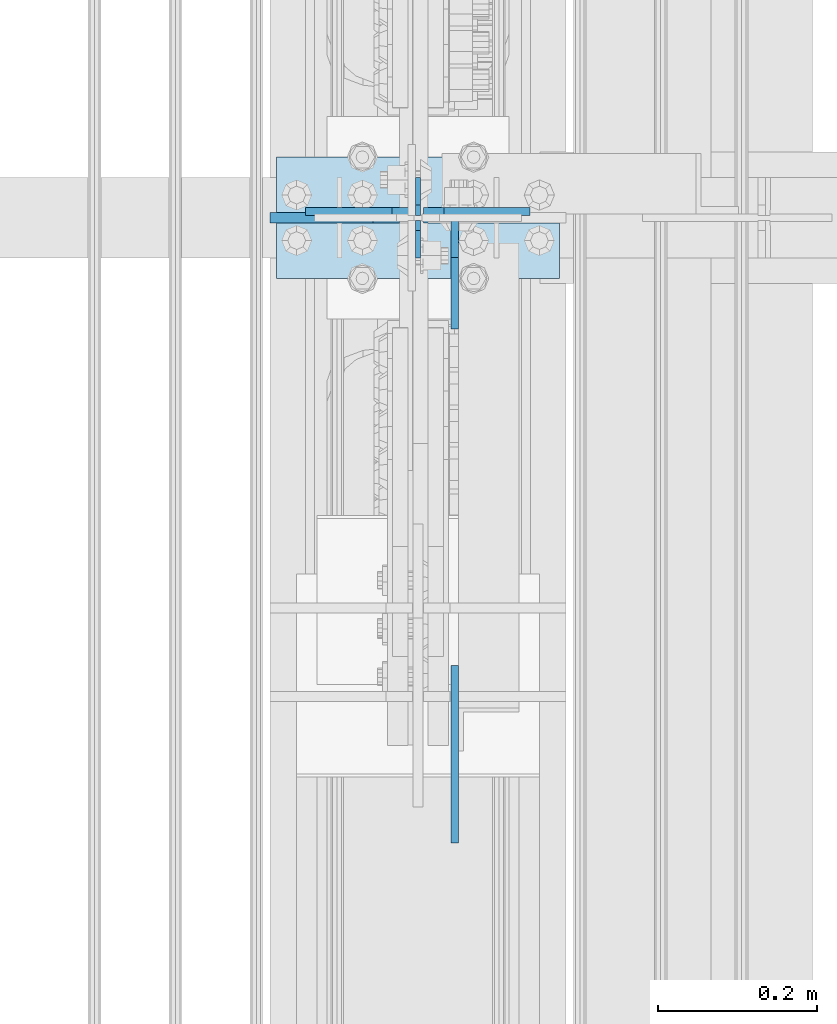
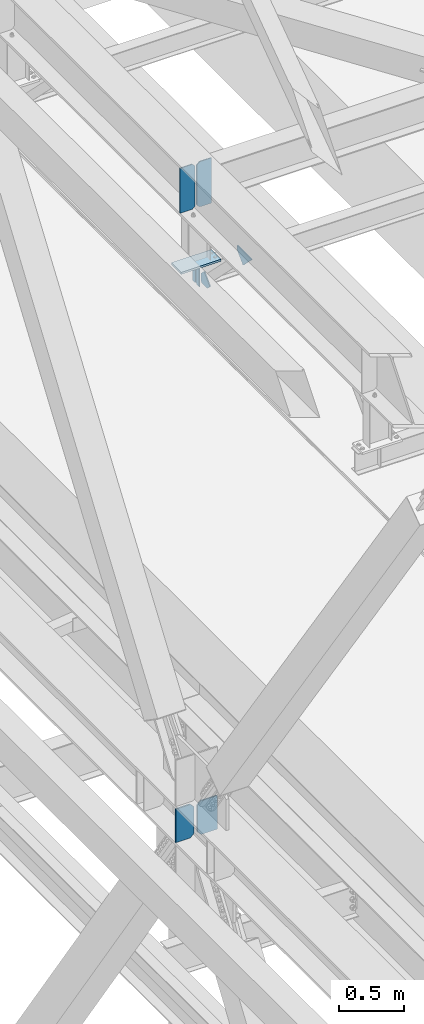
# One storey, part 3348 of 3843: 9 plates, 4 elements without a shape of their own.
"""IFC2X3 building model written with IfcOpenShell, lengths in millimetres."""

from ifc_helpers import new_model, si_unit, frame, origin_with_axes, place, context, subcontext, project, spatial, faceted_brep, material, type_object, element, aggregate, save


model = new_model("IFC2X3")

# Units and contexts
model_context = context("Model", 3, precision=1e-05, world=origin_with_axes())
body_context = subcontext(model_context, "Body", "Model", "MODEL_VIEW")
ifc_project = project(units=[si_unit("LENGTHUNIT", "METRE", prefix="MILLI"), si_unit("AREAUNIT", "SQUARE_METRE"), si_unit("VOLUMEUNIT", "CUBIC_METRE"), si_unit("MASSUNIT", "GRAM", prefix="KILO"), si_unit("TIMEUNIT", "SECOND"), si_unit("PLANEANGLEUNIT", "RADIAN"), si_unit("SOLIDANGLEUNIT", "STERADIAN"), si_unit("THERMODYNAMICTEMPERATUREUNIT", "DEGREE_CELSIUS"), si_unit("LUMINOUSINTENSITYUNIT", "LUMEN")], contexts=[model_context])

# Site, building, storey
site_placement = place(None, origin_with_axes())
site = spatial("IfcSite", under=ifc_project, at=site_placement, CompositionType="ELEMENT")
building_placement = place(site_placement, origin_with_axes())
building = spatial("IfcBuilding", under=site, at=building_placement, Name="Undefined", CompositionType="ELEMENT")
storey_placement = place(building_placement, origin_with_axes())
storey = spatial("IfcBuildingStorey", under=building, at=storey_placement, Name="Undefined", CompositionType="ELEMENT", Elevation=0.0)

# Assembly, plates
assembly_1_placement = place(storey_placement, origin_with_axes())
assembly_1 = element("IfcElementAssembly", 1, at=assembly_1_placement, inside=storey, Name="BEAM", AssemblyPlace="NOTDEFINED", PredefinedType="RIGID_FRAME")
ifc_material = material(Name="STEEL/A572-50")
plate_type_1 = type_object("IfcPlateType", PredefinedType="NOTDEFINED")
plate_1_placement = place(assembly_1_placement, frame((36576.0000030517, 71501.0, 41495.6625), z_axis=(0.0, 0.0, -1.0), x_axis=(0.0, -1.0, 0.0)))
plate_1 = element("IfcPlate", 2, at=plate_1_placement, type_object=plate_type_1, material=ifc_material, Name="PLATE", context=body_context, shape_type="Brep", body=[
    faceted_brep([(0.0, -3.17499999999927, 0.0), (0.0, -3.17500000000291, 187.324999999997), (0.0, 3.17500000000291, 187.324999999997), (0.0, 3.17499999999927, 0.0), (34.9250001907349, -3.17500000000291, 187.324999999997), (34.9250001907349, 3.17500000000291, 187.324999999997), (47.625, -3.17500000000291, 174.625000190732), (47.625, 3.17500000000291, 174.625000190732), (47.625, -3.17499999999927, 12.6999998092651), (47.625, 3.17499999999927, 12.6999998092651), (34.9250001907349, -3.17499999999927, 0.0), (34.9250001907349, 3.17499999999927, 0.0)], [[[0, 1, 2, 3]], [[1, 4, 5, 2]], [[4, 6, 7, 5]], [[6, 8, 9, 7]], [[8, 10, 11, 9]], [[10, 0, 3, 11]], [[5, 7, 9, 11, 3, 2]], [[10, 8, 6, 4, 1, 0]]]),
])
plate_2_placement = place(assembly_1_placement, frame((36576.0000030517, 71399.4, 41495.6625), z_axis=(0.0, 0.0, -1.0), x_axis=(0.0, 1.0, 0.0)))
plate_2 = element("IfcPlate", 3, at=plate_2_placement, type_object=plate_type_1, material=ifc_material, Name="PLATE", context=body_context, shape_type="Brep", body=[
    faceted_brep([(0.0, -3.17499999999927, 0.0), (0.0, -3.17500000000291, 187.324999999997), (0.0, 3.17500000000291, 187.324999999997), (0.0, 3.17499999999927, 0.0), (34.9250001907349, -3.17500000000291, 187.324999999997), (34.9250001907349, 3.17500000000291, 187.324999999997), (47.625, -3.17500000000291, 174.625000190732), (47.625, 3.17500000000291, 174.625000190732), (47.625, -3.17499999999927, 12.6999998092651), (47.625, 3.17499999999927, 12.6999998092651), (34.9250001907349, -3.17499999999927, 0.0), (34.9250001907349, 3.17499999999927, 0.0)], [[[0, 1, 2, 3]], [[1, 4, 5, 2]], [[4, 6, 7, 5]], [[6, 8, 9, 7]], [[8, 10, 11, 9]], [[10, 0, 3, 11]], [[5, 7, 9, 11, 3, 2]], [[10, 8, 6, 4, 1, 0]]]),
])

# Assembly, plate
assembly_2_placement = place(storey_placement, origin_with_axes())
assembly_2 = element("IfcElementAssembly", 4, at=assembly_2_placement, inside=storey, Name="BEAM", AssemblyPlace="NOTDEFINED", PredefinedType="RIGID_FRAME")
plate_type_2 = type_object("IfcPlateType", PredefinedType="NOTDEFINED")
plate_3_placement = place(assembly_2_placement, frame((36583.14375, 71450.199998691, 36093.4), z_axis=(1.0, 0.0, 0.0), x_axis=(0.0, 0.0, 1.0)))
plate_3 = element("IfcPlate", 5, at=plate_3_placement, type_object=plate_type_2, material=ifc_material, Name="CB_BEAM", context=body_context, shape_type="Brep", body=[
    faceted_brep([(0.0, -6.34999999999854, 33.3375015258789), (0.0, -6.34999999999854, 178.59375), (0.0, 6.34999999999854, 178.59375), (0.0, 6.34999999999854, 33.3375015258789), (317.499999999985, -6.34999999999854, 178.59375), (317.499999999985, 6.34999999999854, 178.59375), (317.499999999985, -6.34999999999854, 33.3375015258789), (317.499999999985, 6.34999999999854, 33.3375015258789), (284.162498474107, -6.34999999999854, 0.0), (284.162498474107, 6.34999999999854, 0.0), (33.3375015258789, -6.34999999999854, 0.0), (33.3375015258789, 6.34999999999854, 0.0)], [[[0, 1, 2, 3]], [[1, 4, 5, 2]], [[4, 6, 7, 5]], [[6, 8, 9, 7]], [[8, 10, 11, 9]], [[10, 0, 3, 11]], [[5, 7, 9, 11, 3, 2]], [[10, 8, 6, 4, 1, 0]]]),
])

assembly_3_placement = place(storey_placement, origin_with_axes())
assembly_3 = element("IfcElementAssembly", 6, at=assembly_3_placement, inside=storey, Name="POST", AssemblyPlace="NOTDEFINED", PredefinedType="RIGID_FRAME")
plate_type_3 = type_object("IfcPlateType", PredefinedType="NOTDEFINED")
plate_4_placement = place(assembly_3_placement, frame((36753.8000030518, 71374.0, 41513.125), z_axis=(-1.0, 0.0, 0.0), x_axis=(0.0, 1.0, 0.0)))
plate_4 = element("IfcPlate", 7, at=plate_4_placement, type_object=plate_type_3, material=ifc_material, Name="PLATE", context=body_context, shape_type="Brep", body=[
    faceted_brep([(0.0, -9.52500000000146, 0.0), (0.0, -9.52500000000146, 355.599999999999), (0.0, 9.52500000000146, 355.599999999999), (0.0, 9.52500000000146, 0.0), (152.399999999994, -9.52500000000146, 355.599999999999), (152.399999999994, 9.52500000000146, 355.599999999999), (152.400000000001, -9.52500000000146, 0.0), (152.400000000001, 9.52500000000146, 0.0)], [[[0, 1, 2, 3]], [[1, 4, 5, 2]], [[4, 6, 7, 5]], [[6, 0, 3, 7]], [[5, 7, 3, 2]], [[6, 4, 1, 0]]]),
])
aggregate(assembly_3, [plate_4])

# Assembly, plates
assembly_4_placement = place(storey_placement, origin_with_axes())
assembly_4 = element("IfcElementAssembly", 8, at=assembly_4_placement, inside=storey, Name="BEAM", AssemblyPlace="NOTDEFINED", PredefinedType="RIGID_FRAME")
plate_type_4 = type_object("IfcPlateType", PredefinedType="NOTDEFINED")
plate_5_placement = place(assembly_4_placement, frame((36622.0375, 70664.9789762389, 41995.7250011383), z_axis=(0.0, 0.707106781186548, 0.707106781186548), x_axis=(5.70000238222118e-08, 0.707106781186546, -0.707106781186546)))
plate_5 = element("IfcPlate", 9, at=plate_5_placement, type_object=plate_type_4, material=ifc_material, Name="PLATE", context=body_context, shape_type="Brep", body=[
    faceted_brep([(0.0, -4.76249999999709, 0.0), (157.726597423803, -4.76249999999709, 157.726601438866), (157.726597423803, 4.76249999999709, 157.726601438866), (0.0, 4.76249999999709, 0.0), (188.387110059113, -4.76249999999709, 127.066089584019), (188.387110059113, 4.76249999999709, 127.066089584019), (188.387111679331, -4.76249999999709, 1.09139364212751e-10), (188.387111679331, 4.76249999999709, 1.09139364212751e-10)], [[[0, 1, 2, 3]], [[1, 4, 5, 2]], [[4, 6, 7, 5]], [[6, 0, 3, 7]], [[5, 7, 3, 2]], [[6, 4, 1, 0]]]),
])
plate_6_placement = place(assembly_4_placement, frame((36583.14375, 71458.1379999161, 42019.5375), z_axis=(0.0, 0.0, 1.0), x_axis=(1.0, 0.0, 0.0)))
plate_6 = element("IfcPlate", 10, at=plate_6_placement, type_object=plate_type_4, material=ifc_material, Name="PLATE", context=body_context, shape_type="Brep", body=[
    faceted_brep([(0.0, -4.76249999999709, 25.3999996185303), (0.0, -4.76249999999709, 401.637500381468), (0.0, 4.76249999999709, 401.637500381468), (-2.63229335373174e-12, 4.7625, 25.3999996185303), (25.3999996185303, -4.76249999999709, 427.037499999999), (25.3999996185303, 4.76249999999709, 427.037499999999), (133.349999999999, -4.76249999999709, 427.037499999999), (133.349999999999, 4.76249999999709, 427.037499999999), (133.349999999999, -4.76249999999709, 0.0), (133.349999999999, 4.76249999999709, 0.0), (25.3999996185303, -4.76249999999709, 0.0), (25.3999996185303, 4.7625, 0.0)], [[[0, 1, 2, 3]], [[1, 4, 5, 2]], [[4, 6, 7, 5]], [[6, 8, 9, 7]], [[8, 10, 11, 9]], [[10, 0, 3, 11]], [[5, 7, 9, 11, 3, 2]], [[10, 8, 6, 4, 1, 0]]]),
])

# Plate
plate_type_5 = type_object("IfcPlateType", PredefinedType="NOTDEFINED")
plate_7_placement = place(assembly_1_placement, frame((36622.0375, 71447.025, 41306.75), z_axis=(0.0, -1.0, 0.0), x_axis=(0.0, 0.0, 1.0)))
plate_7 = element("IfcPlate", 11, at=plate_7_placement, type_object=plate_type_5, material=ifc_material, Name="PLATE", context=body_context, shape_type="Brep", body=[
    faceted_brep([(0.0, -4.76250000000073, 12.6999998092651), (4.450703272596e-08, -4.76249999999709, 93.0710244828806), (4.450703272596e-08, 4.76249999999709, 93.0710244828806), (0.0, 4.76250000000073, 12.6999998092651), (43.3137807601452, -4.76249999999709, 136.384805065652), (43.3137807601452, 4.76249999999709, 136.384805065652), (133.209805202001, -4.76249999999709, 46.4887805392646), (133.209805202001, 4.76249999999709, 46.4887805392646), (86.7210245267561, -4.76249999999709, 0.0), (86.7210245267561, 4.76249999999709, 0.0), (12.6999998092651, -4.76250000000073, 0.0), (12.6999998092651, 4.76250000000073, 0.0)], [[[0, 1, 2, 3]], [[1, 4, 5, 2]], [[4, 6, 7, 5]], [[6, 8, 9, 7]], [[8, 10, 11, 9]], [[10, 0, 3, 11]], [[5, 7, 9, 11, 3, 2]], [[10, 8, 6, 4, 1, 0]]]),
])

aggregate(assembly_1, [plate_1, plate_2, plate_7])

plate_type_6 = type_object("IfcPlateType", PredefinedType="NOTDEFINED")
plate_8_placement = place(assembly_4_placement, frame((36568.85625, 71458.137999916, 42019.5375), z_axis=(0.0, 0.0, 1.0), x_axis=(-1.0, 0.0, 0.0)))
plate_8 = element("IfcPlate", 12, at=plate_8_placement, type_object=plate_type_6, material=ifc_material, Name="PLATE", context=body_context, shape_type="Brep", body=[
    faceted_brep([(0.0, -4.76249999999709, 25.3999996185303), (0.0, -4.76249999999709, 400.050000381467), (0.0, 4.76249999999709, 400.050000381467), (-2.63229335373174e-12, 4.7625, 25.3999996185303), (25.3999996185303, -4.76249999999709, 425.449999999997), (25.3999996185303, 4.76249999999709, 425.449999999997), (134.143750000047, -4.76249999999709, 425.449999999997), (134.143750000047, 4.76249999999709, 425.449999999997), (134.143750000047, -4.76249999999709, 0.0), (134.143750000047, 4.76249999999709, 0.0), (25.3999996185303, -4.76249999999709, 0.0), (25.3999996185303, 4.7625, 0.0)], [[[0, 1, 2, 3]], [[1, 4, 5, 2]], [[4, 6, 7, 5]], [[6, 8, 9, 7]], [[8, 10, 11, 9]], [[10, 0, 3, 11]], [[5, 7, 9, 11, 3, 2]], [[10, 8, 6, 4, 1, 0]]]),
])

aggregate(assembly_4, [plate_5, plate_8, plate_6])

plate_type_7 = type_object("IfcPlateType", PredefinedType="NOTDEFINED")
plate_9_placement = place(assembly_2_placement, frame((36552.98125, 71450.199998691, 36093.4), z_axis=(-1.0, 0.0, 0.0), x_axis=(0.0, 0.0, 1.0)))
plate_9 = element("IfcPlate", 13, at=plate_9_placement, type_object=plate_type_7, material=ifc_material, Name="CB_BEAM", context=body_context, shape_type="Brep", body=[
    faceted_brep([(0.0, -6.34999999999854, 33.3375015258789), (0.0, -6.35000000000582, 162.71875), (0.0, 6.35000000000582, 162.71875), (0.0, 6.34999999999854, 33.3375015258789), (317.5, -6.35000000000582, 162.71875), (317.5, 6.35000000000582, 162.71875), (317.499999999985, -6.34999999999854, 33.3375015258789), (317.499999999985, 6.34999999999854, 33.3375015258789), (284.162498474107, -6.34999999999854, 0.0), (284.162498474107, 6.34999999999854, 0.0), (33.3375015258789, -6.34999999999854, 0.0), (33.3375015258789, 6.34999999999854, 0.0)], [[[0, 1, 2, 3]], [[1, 4, 5, 2]], [[4, 6, 7, 5]], [[6, 8, 9, 7]], [[8, 10, 11, 9]], [[10, 0, 3, 11]], [[5, 7, 9, 11, 3, 2]], [[10, 8, 6, 4, 1, 0]]]),
])

aggregate(assembly_2, [plate_9, plate_3])

save(model, "model.ifc")
